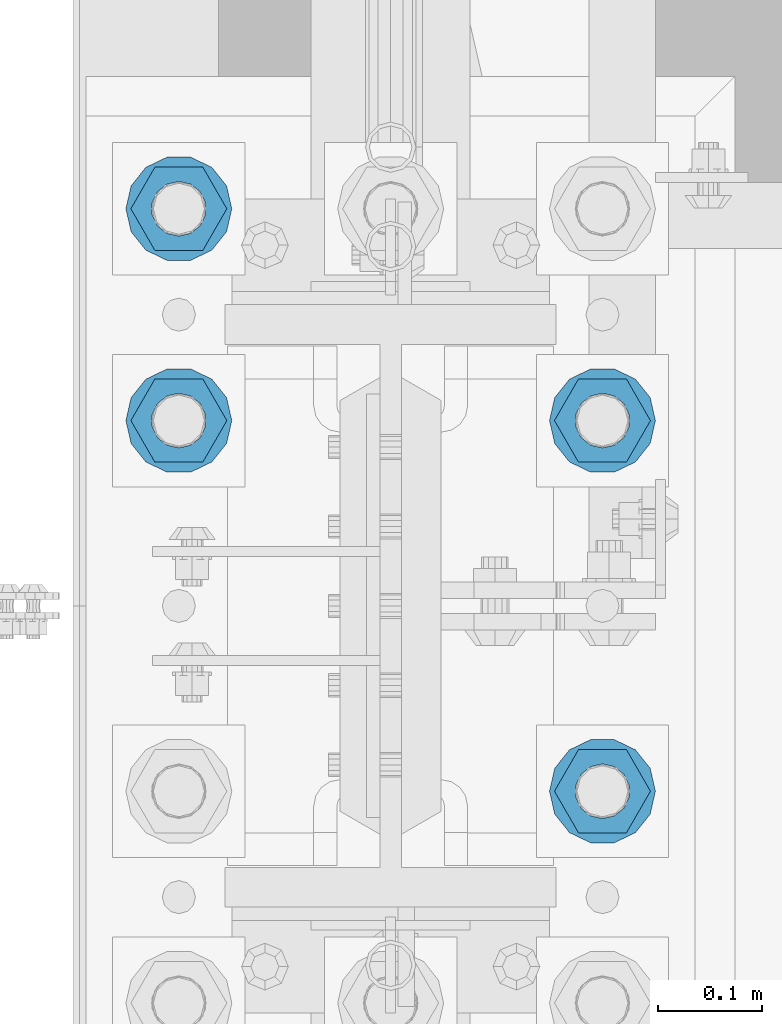
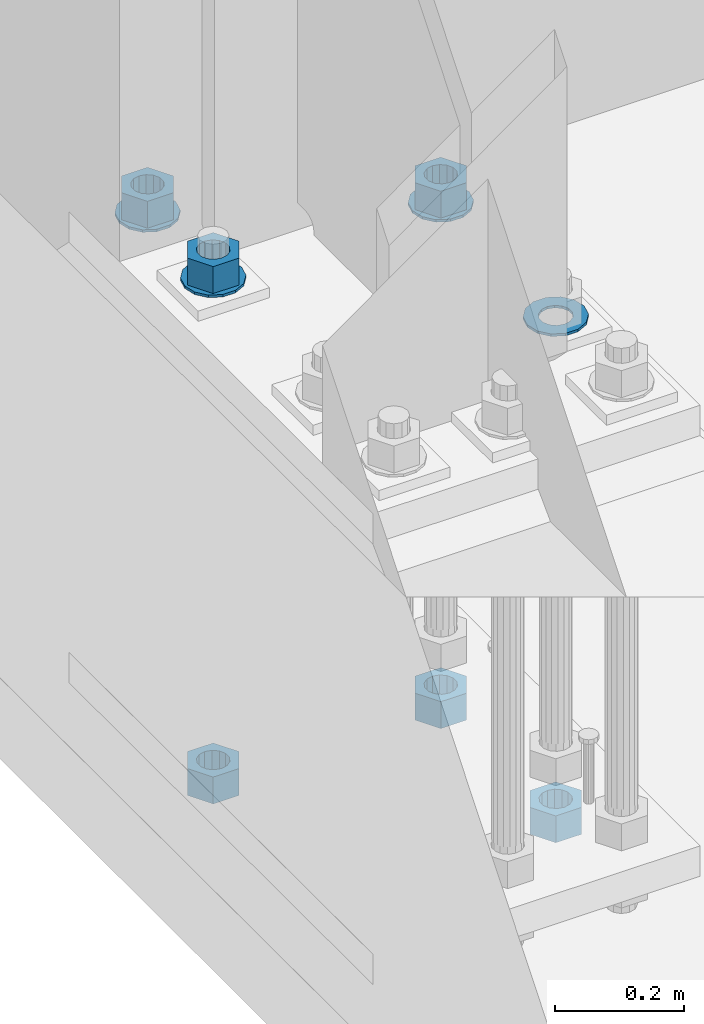
# One storey, part 836 of 1876: 10 columns, 1 element without a shape of its own.
"""IFC2X3 building model written with IfcOpenShell, lengths in millimetres."""

from ifc_helpers import new_model, si_unit, frame, origin_with_axes, place, context, subcontext, project, spatial, faceted_brep, material, type_object, element, aggregate, save


model = new_model("IFC2X3")

# Units and contexts
model_context = context("Model", 3, precision=1e-05, world=origin_with_axes())
body_context = subcontext(model_context, "Body", "Model", "MODEL_VIEW")
ifc_project = project(units=[si_unit("LENGTHUNIT", "METRE", prefix="MILLI"), si_unit("AREAUNIT", "SQUARE_METRE"), si_unit("VOLUMEUNIT", "CUBIC_METRE"), si_unit("MASSUNIT", "GRAM", prefix="KILO"), si_unit("TIMEUNIT", "SECOND"), si_unit("PLANEANGLEUNIT", "RADIAN"), si_unit("SOLIDANGLEUNIT", "STERADIAN"), si_unit("THERMODYNAMICTEMPERATUREUNIT", "DEGREE_CELSIUS"), si_unit("LUMINOUSINTENSITYUNIT", "LUMEN")], contexts=[model_context])

# Site, building, storey
site_placement = place(None, origin_with_axes())
site = spatial("IfcSite", under=ifc_project, at=site_placement, CompositionType="ELEMENT")
building_placement = place(site_placement, origin_with_axes())
building = spatial("IfcBuilding", under=site, at=building_placement, Name="Undefined", CompositionType="ELEMENT")
storey_placement = place(building_placement, origin_with_axes())
storey = spatial("IfcBuildingStorey", under=building, at=storey_placement, Name="Undefined", CompositionType="ELEMENT", Elevation=0.0)

# Assembly, columns
assembly_placement = place(storey_placement, origin_with_axes())
assembly = element("IfcElementAssembly", 1, at=assembly_placement, inside=storey, Name="TEMPLATE", AssemblyPlace="NOTDEFINED", PredefinedType="RIGID_FRAME")
ifc_material_1 = material(Name="STEEL/F436")
column_type_1 = type_object("IfcColumnType", Name="2_WASHER", PredefinedType="NOTDEFINED")
column_1_placement = place(assembly_placement, frame((203.2, 1346.2, 119.0625), z_axis=(0.0, 1.0, 0.0), x_axis=(0.0, 0.0, -1.0)))
column_1 = element("IfcColumn", 2, at=column_1_placement, type_object=column_type_1, material=ifc_material_1, Name="WASHER", ObjectType="2_WASHER", context=body_context, shape_type="Brep", body=[
    faceted_brep([(0.0, -50.7999992370605, 9.09494701772928e-13), (0.0, -45.7692178020588, -22.0412936161442), (4.7625, -45.7692178020588, -22.0412936161442), (4.7625, -50.7999992370605, 9.09494701772928e-13), (0.0, -31.6732814587394, -39.7170387128856), (4.7625, -31.6732814587394, -39.7170387128856), (0.0, -11.3040632752118, -49.5263371950259), (4.7625, -11.3040632752118, -49.5263371950259), (0.0, 11.30406327521, -49.5263371950264), (4.7625, 11.30406327521, -49.5263371950264), (0.0, 31.6732814587385, -39.7170387128867), (4.7625, 31.6732814587385, -39.7170387128867), (0.0, 45.7692178020579, -22.041293616146), (4.7625, 45.7692178020579, -22.041293616146), (0.0, 50.7999992370605, -9.09494701772928e-13), (4.7625, 50.7999992370605, -9.09494701772928e-13), (0.0, 45.7692178020588, 22.0412936161442), (4.7625, 45.7692178020588, 22.0412936161442), (0.0, 31.6732814587394, 39.7170387128856), (4.7625, 31.6732814587394, 39.7170387128856), (0.0, 11.3040632752118, 49.5263371950259), (4.7625, 11.3040632752118, 49.5263371950259), (0.0, -11.30406327521, 49.5263371950264), (4.7625, -11.30406327521, 49.5263371950264), (0.0, -31.6732814587385, 39.7170387128867), (4.7625, -31.6732814587385, 39.7170387128867), (0.0, -45.7692178020579, 22.041293616146), (4.7625, -45.7692178020579, 22.041293616146), (0.0, 0.0, 26.9869995117188), (0.0, 11.7093983825444, 24.3146012721213), (4.7625, 11.7093983825444, 24.3146012721213), (4.7625, 0.0, 26.9869995117188), (0.0, 21.0996520289491, 16.8262864224157), (4.7625, 21.0996520289491, 16.8262864224157), (0.0, 26.3108629296712, 6.00524193584533), (4.7625, 26.3108629296712, 6.00524193584533), (0.0, 26.3108629296712, -6.00524193584533), (4.7625, 26.3108629296712, -6.00524193584533), (0.0, 21.0996520289491, -16.8262864224157), (4.7625, 21.0996520289491, -16.8262864224157), (0.0, 11.7093983825444, -24.3146012721213), (4.7625, 11.7093983825444, -24.3146012721213), (0.0, 0.0, -26.9869995117188), (4.7625, 0.0, -26.9869995117188), (0.0, -11.7093983825444, -24.3146012721213), (4.7625, -11.7093983825444, -24.3146012721213), (0.0, -21.0996520289491, -16.8262864224157), (4.7625, -21.0996520289491, -16.8262864224157), (0.0, -26.3108629296712, -6.00524193584533), (4.7625, -26.3108629296712, -6.00524193584533), (0.0, -26.3108629296712, 6.00524193584533), (4.7625, -26.3108629296712, 6.00524193584533), (0.0, -21.0996520289491, 16.8262864224157), (4.7625, -21.0996520289491, 16.8262864224157), (0.0, -11.7093983825444, 24.3146012721213), (4.7625, -11.7093983825444, 24.3146012721213)], [[[0, 1, 2, 3]], [[1, 4, 5, 2]], [[4, 6, 7, 5]], [[6, 8, 9, 7]], [[8, 10, 11, 9]], [[10, 12, 13, 11]], [[12, 14, 15, 13]], [[14, 16, 17, 15]], [[16, 18, 19, 17]], [[18, 20, 21, 19]], [[20, 22, 23, 21]], [[22, 24, 25, 23]], [[24, 26, 27, 25]], [[26, 0, 3, 27]], [[28, 29, 30, 31]], [[29, 32, 33, 30]], [[32, 34, 35, 33]], [[34, 36, 37, 35]], [[36, 38, 39, 37]], [[38, 40, 41, 39]], [[40, 42, 43, 41]], [[42, 44, 45, 43]], [[44, 46, 47, 45]], [[46, 48, 49, 47]], [[48, 50, 51, 49]], [[50, 52, 53, 51]], [[52, 54, 55, 53]], [[54, 28, 31, 55]], [[5, 7, 9, 11, 13, 15, 17, 19, 21, 23, 25, 27, 3, 2], [33, 35, 37, 39, 41, 43, 45, 47, 49, 51, 53, 55, 31, 30]], [[26, 24, 22, 20, 18, 16, 14, 12, 10, 8, 6, 4, 1, 0], [54, 52, 50, 48, 46, 44, 42, 40, 38, 36, 34, 32, 29, 28]]]),
])
column_2_placement = place(assembly_placement, frame((-203.2, 1701.8, 119.0625), z_axis=(0.0, -1.0, 0.0), x_axis=(0.0, 0.0, -1.0)))
column_2 = element("IfcColumn", 3, at=column_2_placement, type_object=column_type_1, material=ifc_material_1, Name="WASHER", ObjectType="2_WASHER", context=body_context, shape_type="Brep", body=[
    faceted_brep([(0.0, -50.7999992370605, 9.09494701772928e-13), (0.0, -45.7692178020588, -22.0412936161442), (4.7625, -45.7692178020588, -22.0412936161442), (4.7625, -50.7999992370605, 9.09494701772928e-13), (0.0, -31.6732814587394, -39.7170387128856), (4.7625, -31.6732814587394, -39.7170387128856), (0.0, -11.3040632752118, -49.5263371950259), (4.7625, -11.3040632752118, -49.5263371950259), (0.0, 11.30406327521, -49.5263371950264), (4.7625, 11.30406327521, -49.5263371950264), (0.0, 31.6732814587385, -39.7170387128867), (4.7625, 31.6732814587385, -39.7170387128867), (0.0, 45.7692178020579, -22.041293616146), (4.7625, 45.7692178020579, -22.041293616146), (0.0, 50.7999992370605, -9.09494701772928e-13), (4.7625, 50.7999992370605, -9.09494701772928e-13), (0.0, 45.7692178020588, 22.0412936161442), (4.7625, 45.7692178020588, 22.0412936161442), (0.0, 31.6732814587394, 39.7170387128856), (4.7625, 31.6732814587394, 39.7170387128856), (0.0, 11.3040632752118, 49.5263371950259), (4.7625, 11.3040632752118, 49.5263371950259), (0.0, -11.30406327521, 49.5263371950264), (4.7625, -11.30406327521, 49.5263371950264), (0.0, -31.6732814587385, 39.7170387128867), (4.7625, -31.6732814587385, 39.7170387128867), (0.0, -45.7692178020579, 22.041293616146), (4.7625, -45.7692178020579, 22.041293616146), (0.0, 0.0, 26.9869995117188), (0.0, 11.7093983825444, 24.3146012721213), (4.7625, 11.7093983825444, 24.3146012721213), (4.7625, 0.0, 26.9869995117188), (0.0, 21.0996520289491, 16.8262864224157), (4.7625, 21.0996520289491, 16.8262864224157), (0.0, 26.3108629296712, 6.00524193584533), (4.7625, 26.3108629296712, 6.00524193584533), (0.0, 26.3108629296712, -6.00524193584533), (4.7625, 26.3108629296712, -6.00524193584533), (0.0, 21.0996520289491, -16.8262864224157), (4.7625, 21.0996520289491, -16.8262864224157), (0.0, 11.7093983825444, -24.3146012721213), (4.7625, 11.7093983825444, -24.3146012721213), (0.0, 0.0, -26.9869995117188), (4.7625, 0.0, -26.9869995117188), (0.0, -11.7093983825444, -24.3146012721213), (4.7625, -11.7093983825444, -24.3146012721213), (0.0, -21.0996520289491, -16.8262864224157), (4.7625, -21.0996520289491, -16.8262864224157), (0.0, -26.3108629296712, -6.00524193584533), (4.7625, -26.3108629296712, -6.00524193584533), (0.0, -26.3108629296712, 6.00524193584533), (4.7625, -26.3108629296712, 6.00524193584533), (0.0, -21.0996520289491, 16.8262864224157), (4.7625, -21.0996520289491, 16.8262864224157), (0.0, -11.7093983825444, 24.3146012721213), (4.7625, -11.7093983825444, 24.3146012721213)], [[[0, 1, 2, 3]], [[1, 4, 5, 2]], [[4, 6, 7, 5]], [[6, 8, 9, 7]], [[8, 10, 11, 9]], [[10, 12, 13, 11]], [[12, 14, 15, 13]], [[14, 16, 17, 15]], [[16, 18, 19, 17]], [[18, 20, 21, 19]], [[20, 22, 23, 21]], [[22, 24, 25, 23]], [[24, 26, 27, 25]], [[26, 0, 3, 27]], [[28, 29, 30, 31]], [[29, 32, 33, 30]], [[32, 34, 35, 33]], [[34, 36, 37, 35]], [[36, 38, 39, 37]], [[38, 40, 41, 39]], [[40, 42, 43, 41]], [[42, 44, 45, 43]], [[44, 46, 47, 45]], [[46, 48, 49, 47]], [[48, 50, 51, 49]], [[50, 52, 53, 51]], [[52, 54, 55, 53]], [[54, 28, 31, 55]], [[5, 7, 9, 11, 13, 15, 17, 19, 21, 23, 25, 27, 3, 2], [33, 35, 37, 39, 41, 43, 45, 47, 49, 51, 53, 55, 31, 30]], [[26, 24, 22, 20, 18, 16, 14, 12, 10, 8, 6, 4, 1, 0], [54, 52, 50, 48, 46, 44, 42, 40, 38, 36, 34, 32, 29, 28]]]),
])
column_3_placement = place(assembly_placement, frame((203.2, 1701.8, 119.0625), z_axis=(0.0, 1.0, 0.0), x_axis=(0.0, 0.0, -1.0)))
column_3 = element("IfcColumn", 4, at=column_3_placement, type_object=column_type_1, material=ifc_material_1, Name="WASHER", ObjectType="2_WASHER", context=body_context, shape_type="Brep", body=[
    faceted_brep([(0.0, -50.7999992370605, 9.09494701772928e-13), (0.0, -45.7692178020588, -22.0412936161442), (4.7625, -45.7692178020588, -22.0412936161442), (4.7625, -50.7999992370605, 9.09494701772928e-13), (0.0, -31.6732814587394, -39.7170387128856), (4.7625, -31.6732814587394, -39.7170387128856), (0.0, -11.3040632752118, -49.5263371950259), (4.7625, -11.3040632752118, -49.5263371950259), (0.0, 11.30406327521, -49.5263371950264), (4.7625, 11.30406327521, -49.5263371950264), (0.0, 31.6732814587385, -39.7170387128867), (4.7625, 31.6732814587385, -39.7170387128867), (0.0, 45.7692178020579, -22.041293616146), (4.7625, 45.7692178020579, -22.041293616146), (0.0, 50.7999992370605, -9.09494701772928e-13), (4.7625, 50.7999992370605, -9.09494701772928e-13), (0.0, 45.7692178020588, 22.0412936161442), (4.7625, 45.7692178020588, 22.0412936161442), (0.0, 31.6732814587394, 39.7170387128856), (4.7625, 31.6732814587394, 39.7170387128856), (0.0, 11.3040632752118, 49.5263371950259), (4.7625, 11.3040632752118, 49.5263371950259), (0.0, -11.30406327521, 49.5263371950264), (4.7625, -11.30406327521, 49.5263371950264), (0.0, -31.6732814587385, 39.7170387128867), (4.7625, -31.6732814587385, 39.7170387128867), (0.0, -45.7692178020579, 22.041293616146), (4.7625, -45.7692178020579, 22.041293616146), (0.0, 0.0, 26.9869995117188), (0.0, 11.7093983825444, 24.3146012721213), (4.7625, 11.7093983825444, 24.3146012721213), (4.7625, 0.0, 26.9869995117188), (0.0, 21.0996520289491, 16.8262864224157), (4.7625, 21.0996520289491, 16.8262864224157), (0.0, 26.3108629296712, 6.00524193584533), (4.7625, 26.3108629296712, 6.00524193584533), (0.0, 26.3108629296712, -6.00524193584533), (4.7625, 26.3108629296712, -6.00524193584533), (0.0, 21.0996520289491, -16.8262864224157), (4.7625, 21.0996520289491, -16.8262864224157), (0.0, 11.7093983825444, -24.3146012721213), (4.7625, 11.7093983825444, -24.3146012721213), (0.0, 0.0, -26.9869995117188), (4.7625, 0.0, -26.9869995117188), (0.0, -11.7093983825444, -24.3146012721213), (4.7625, -11.7093983825444, -24.3146012721213), (0.0, -21.0996520289491, -16.8262864224157), (4.7625, -21.0996520289491, -16.8262864224157), (0.0, -26.3108629296712, -6.00524193584533), (4.7625, -26.3108629296712, -6.00524193584533), (0.0, -26.3108629296712, 6.00524193584533), (4.7625, -26.3108629296712, 6.00524193584533), (0.0, -21.0996520289491, 16.8262864224157), (4.7625, -21.0996520289491, 16.8262864224157), (0.0, -11.7093983825444, 24.3146012721213), (4.7625, -11.7093983825444, 24.3146012721213)], [[[0, 1, 2, 3]], [[1, 4, 5, 2]], [[4, 6, 7, 5]], [[6, 8, 9, 7]], [[8, 10, 11, 9]], [[10, 12, 13, 11]], [[12, 14, 15, 13]], [[14, 16, 17, 15]], [[16, 18, 19, 17]], [[18, 20, 21, 19]], [[20, 22, 23, 21]], [[22, 24, 25, 23]], [[24, 26, 27, 25]], [[26, 0, 3, 27]], [[28, 29, 30, 31]], [[29, 32, 33, 30]], [[32, 34, 35, 33]], [[34, 36, 37, 35]], [[36, 38, 39, 37]], [[38, 40, 41, 39]], [[40, 42, 43, 41]], [[42, 44, 45, 43]], [[44, 46, 47, 45]], [[46, 48, 49, 47]], [[48, 50, 51, 49]], [[50, 52, 53, 51]], [[52, 54, 55, 53]], [[54, 28, 31, 55]], [[5, 7, 9, 11, 13, 15, 17, 19, 21, 23, 25, 27, 3, 2], [33, 35, 37, 39, 41, 43, 45, 47, 49, 51, 53, 55, 31, 30]], [[26, 24, 22, 20, 18, 16, 14, 12, 10, 8, 6, 4, 1, 0], [54, 52, 50, 48, 46, 44, 42, 40, 38, 36, 34, 32, 29, 28]]]),
])
column_4_placement = place(assembly_placement, frame((-203.2, 1905.0, 119.0625), z_axis=(0.0, -1.0, 0.0), x_axis=(0.0, 0.0, -1.0)))
column_4 = element("IfcColumn", 5, at=column_4_placement, type_object=column_type_1, material=ifc_material_1, Name="WASHER", ObjectType="2_WASHER", context=body_context, shape_type="Brep", body=[
    faceted_brep([(0.0, -50.7999992370605, 9.09494701772928e-13), (0.0, -45.7692178020588, -22.0412936161442), (4.7625, -45.7692178020588, -22.0412936161442), (4.7625, -50.7999992370605, 9.09494701772928e-13), (0.0, -31.6732814587394, -39.7170387128856), (4.7625, -31.6732814587394, -39.7170387128856), (0.0, -11.3040632752118, -49.5263371950259), (4.7625, -11.3040632752118, -49.5263371950259), (0.0, 11.30406327521, -49.5263371950264), (4.7625, 11.30406327521, -49.5263371950264), (0.0, 31.6732814587385, -39.7170387128867), (4.7625, 31.6732814587385, -39.7170387128867), (0.0, 45.7692178020579, -22.041293616146), (4.7625, 45.7692178020579, -22.041293616146), (0.0, 50.7999992370605, -9.09494701772928e-13), (4.7625, 50.7999992370605, -9.09494701772928e-13), (0.0, 45.7692178020588, 22.0412936161442), (4.7625, 45.7692178020588, 22.0412936161442), (0.0, 31.6732814587394, 39.7170387128856), (4.7625, 31.6732814587394, 39.7170387128856), (0.0, 11.3040632752118, 49.5263371950259), (4.7625, 11.3040632752118, 49.5263371950259), (0.0, -11.30406327521, 49.5263371950264), (4.7625, -11.30406327521, 49.5263371950264), (0.0, -31.6732814587385, 39.7170387128867), (4.7625, -31.6732814587385, 39.7170387128867), (0.0, -45.7692178020579, 22.041293616146), (4.7625, -45.7692178020579, 22.041293616146), (0.0, 0.0, 26.9869995117188), (0.0, 11.7093983825444, 24.3146012721213), (4.7625, 11.7093983825444, 24.3146012721213), (4.7625, 0.0, 26.9869995117188), (0.0, 21.0996520289491, 16.8262864224157), (4.7625, 21.0996520289491, 16.8262864224157), (0.0, 26.3108629296712, 6.00524193584533), (4.7625, 26.3108629296712, 6.00524193584533), (0.0, 26.3108629296712, -6.00524193584533), (4.7625, 26.3108629296712, -6.00524193584533), (0.0, 21.0996520289491, -16.8262864224157), (4.7625, 21.0996520289491, -16.8262864224157), (0.0, 11.7093983825444, -24.3146012721213), (4.7625, 11.7093983825444, -24.3146012721213), (0.0, 0.0, -26.9869995117188), (4.7625, 0.0, -26.9869995117188), (0.0, -11.7093983825444, -24.3146012721213), (4.7625, -11.7093983825444, -24.3146012721213), (0.0, -21.0996520289491, -16.8262864224157), (4.7625, -21.0996520289491, -16.8262864224157), (0.0, -26.3108629296712, -6.00524193584533), (4.7625, -26.3108629296712, -6.00524193584533), (0.0, -26.3108629296712, 6.00524193584533), (4.7625, -26.3108629296712, 6.00524193584533), (0.0, -21.0996520289491, 16.8262864224157), (4.7625, -21.0996520289491, 16.8262864224157), (0.0, -11.7093983825444, 24.3146012721213), (4.7625, -11.7093983825444, 24.3146012721213)], [[[0, 1, 2, 3]], [[1, 4, 5, 2]], [[4, 6, 7, 5]], [[6, 8, 9, 7]], [[8, 10, 11, 9]], [[10, 12, 13, 11]], [[12, 14, 15, 13]], [[14, 16, 17, 15]], [[16, 18, 19, 17]], [[18, 20, 21, 19]], [[20, 22, 23, 21]], [[22, 24, 25, 23]], [[24, 26, 27, 25]], [[26, 0, 3, 27]], [[28, 29, 30, 31]], [[29, 32, 33, 30]], [[32, 34, 35, 33]], [[34, 36, 37, 35]], [[36, 38, 39, 37]], [[38, 40, 41, 39]], [[40, 42, 43, 41]], [[42, 44, 45, 43]], [[44, 46, 47, 45]], [[46, 48, 49, 47]], [[48, 50, 51, 49]], [[50, 52, 53, 51]], [[52, 54, 55, 53]], [[54, 28, 31, 55]], [[5, 7, 9, 11, 13, 15, 17, 19, 21, 23, 25, 27, 3, 2], [33, 35, 37, 39, 41, 43, 45, 47, 49, 51, 53, 55, 31, 30]], [[26, 24, 22, 20, 18, 16, 14, 12, 10, 8, 6, 4, 1, 0], [54, 52, 50, 48, 46, 44, 42, 40, 38, 36, 34, 32, 29, 28]]]),
])
ifc_material_2 = material(Name="STEEL/A563")
column_type_2 = type_object("IfcColumnType", Name="2_HEAVY_HEX_NUT", PredefinedType="NOTDEFINED")
column_5_placement = place(assembly_placement, frame((203.2, 1346.2, -793.75), z_axis=(0.0, 1.0, 0.0), x_axis=(0.0, 0.0, -1.0)))
column_5 = element("IfcColumn", 6, at=column_5_placement, type_object=column_type_2, material=ifc_material_2, Name="NUT", ObjectType="2_HEAVY_HEX_NUT", context=body_context, shape_type="Brep", body=[
    faceted_brep([(0.0, -46.0369987487793, 9.09494701772928e-13), (0.0, -23.0184993743896, -39.869213104248), (50.8, -23.0184993743896, -39.869213104248), (50.8, -46.0369987487793, 9.09494701772928e-13), (0.0, 23.0184993743896, -39.869213104248), (50.8, 23.0184993743896, -39.869213104248), (0.0, 46.0369987487793, -9.09494701772928e-13), (50.8, 46.0369987487793, -9.09494701772928e-13), (0.0, 23.0184993743896, 39.869213104248), (50.8, 23.0184993743896, 39.869213104248), (0.0, -23.0184993743896, 39.869213104248), (50.8, -23.0184993743896, 39.869213104248), (0.0, 0.0, 26.1940002441406), (0.0, 11.3650617044514, 23.5999013092769), (50.8, 11.3650617044513, 23.5999013092771), (50.8, 0.0, 26.1940002441406), (0.0, 20.4791109456437, 16.3316083006703), (50.8, 20.4791109456439, 16.3316083006703), (0.0, 25.5370200498346, 5.82867859874477), (50.8, 25.5370200498343, 5.82867859874455), (0.0, 25.5370200498346, -5.82867859874477), (50.8, 25.5370200498343, -5.82867859874455), (0.0, 20.4791109456437, -16.3316083006703), (50.8, 20.4791109456439, -16.3316083006703), (0.0, 11.3650617044514, -23.5999013092769), (50.8, 11.3650617044514, -23.5999013092771), (0.0, 0.0, -26.1940002441406), (50.8, 0.0, -26.1940002441406), (0.0, -11.3650617044514, -23.5999013092769), (50.8, -11.3650617044513, -23.5999013092771), (0.0, -20.4791109456437, -16.3316083006703), (50.8, -20.4791109456439, -16.3316083006703), (0.0, -25.5370200498346, -5.82867859874477), (50.8, -25.5370200498343, -5.82867859874455), (0.0, -25.5370200498346, 5.82867859874477), (50.8, -25.5370200498343, 5.82867859874455), (0.0, -20.4791109456437, 16.3316083006703), (50.8, -20.4791109456439, 16.3316083006703), (0.0, -11.3650617044514, 23.5999013092769), (50.8, -11.3650617044514, 23.5999013092771)], [[[0, 1, 2, 3]], [[1, 4, 5, 2]], [[4, 6, 7, 5]], [[6, 8, 9, 7]], [[8, 10, 11, 9]], [[10, 0, 3, 11]], [[12, 13, 14, 15]], [[13, 16, 17, 14]], [[16, 18, 19, 17]], [[18, 20, 21, 19]], [[20, 22, 23, 21]], [[22, 24, 25, 23]], [[24, 26, 27, 25]], [[26, 28, 29, 27]], [[28, 30, 31, 29]], [[30, 32, 33, 31]], [[32, 34, 35, 33]], [[34, 36, 37, 35]], [[36, 38, 39, 37]], [[38, 12, 15, 39]], [[5, 7, 9, 11, 3, 2], [17, 19, 21, 23, 25, 27, 29, 31, 33, 35, 37, 39, 15, 14]], [[10, 8, 6, 4, 1, 0], [38, 36, 34, 32, 30, 28, 26, 24, 22, 20, 18, 16, 13, 12]]]),
])
column_6_placement = place(assembly_placement, frame((-203.2, 1701.8, 169.8625), z_axis=(0.0, -1.0, 0.0), x_axis=(0.0, 0.0, -1.0)))
column_6 = element("IfcColumn", 7, at=column_6_placement, type_object=column_type_2, material=ifc_material_2, Name="NUT", ObjectType="2_HEAVY_HEX_NUT", context=body_context, shape_type="Brep", body=[
    faceted_brep([(0.0, -46.0369987487793, 9.09494701772928e-13), (0.0, -23.0184993743896, -39.869213104248), (50.8, -23.0184993743896, -39.869213104248), (50.8, -46.0369987487793, 9.09494701772928e-13), (0.0, 23.0184993743896, -39.869213104248), (50.8, 23.0184993743896, -39.869213104248), (0.0, 46.0369987487793, -9.09494701772928e-13), (50.8, 46.0369987487793, -9.09494701772928e-13), (0.0, 23.0184993743896, 39.869213104248), (50.8, 23.0184993743896, 39.869213104248), (0.0, -23.0184993743896, 39.869213104248), (50.8, -23.0184993743896, 39.869213104248), (0.0, 0.0, 26.1940002441406), (0.0, 11.3650617044514, 23.5999013092769), (50.8, 11.3650617044513, 23.5999013092771), (50.8, 0.0, 26.1940002441406), (0.0, 20.4791109456437, 16.3316083006703), (50.8, 20.4791109456439, 16.3316083006703), (0.0, 25.5370200498346, 5.82867859874477), (50.8, 25.5370200498343, 5.82867859874455), (0.0, 25.5370200498346, -5.82867859874477), (50.8, 25.5370200498343, -5.82867859874455), (0.0, 20.4791109456437, -16.3316083006703), (50.8, 20.4791109456439, -16.3316083006703), (0.0, 11.3650617044514, -23.5999013092769), (50.8, 11.3650617044514, -23.5999013092771), (0.0, 0.0, -26.1940002441406), (50.8, 0.0, -26.1940002441406), (0.0, -11.3650617044514, -23.5999013092769), (50.8, -11.3650617044513, -23.5999013092771), (0.0, -20.4791109456437, -16.3316083006703), (50.8, -20.4791109456439, -16.3316083006703), (0.0, -25.5370200498346, -5.82867859874477), (50.8, -25.5370200498343, -5.82867859874455), (0.0, -25.5370200498346, 5.82867859874477), (50.8, -25.5370200498343, 5.82867859874455), (0.0, -20.4791109456437, 16.3316083006703), (50.8, -20.4791109456439, 16.3316083006703), (0.0, -11.3650617044514, 23.5999013092769), (50.8, -11.3650617044514, 23.5999013092771)], [[[0, 1, 2, 3]], [[1, 4, 5, 2]], [[4, 6, 7, 5]], [[6, 8, 9, 7]], [[8, 10, 11, 9]], [[10, 0, 3, 11]], [[12, 13, 14, 15]], [[13, 16, 17, 14]], [[16, 18, 19, 17]], [[18, 20, 21, 19]], [[20, 22, 23, 21]], [[22, 24, 25, 23]], [[24, 26, 27, 25]], [[26, 28, 29, 27]], [[28, 30, 31, 29]], [[30, 32, 33, 31]], [[32, 34, 35, 33]], [[34, 36, 37, 35]], [[36, 38, 39, 37]], [[38, 12, 15, 39]], [[5, 7, 9, 11, 3, 2], [17, 19, 21, 23, 25, 27, 29, 31, 33, 35, 37, 39, 15, 14]], [[10, 8, 6, 4, 1, 0], [38, 36, 34, 32, 30, 28, 26, 24, 22, 20, 18, 16, 13, 12]]]),
])
column_7_placement = place(assembly_placement, frame((-203.2, 1701.8, -793.75), z_axis=(0.0, -1.0, 0.0), x_axis=(0.0, 0.0, -1.0)))
column_7 = element("IfcColumn", 8, at=column_7_placement, type_object=column_type_2, material=ifc_material_2, Name="NUT", ObjectType="2_HEAVY_HEX_NUT", context=body_context, shape_type="Brep", body=[
    faceted_brep([(0.0, -46.0369987487793, 9.09494701772928e-13), (0.0, -23.0184993743896, -39.869213104248), (50.8, -23.0184993743896, -39.869213104248), (50.8, -46.0369987487793, 9.09494701772928e-13), (0.0, 23.0184993743896, -39.869213104248), (50.8, 23.0184993743896, -39.869213104248), (0.0, 46.0369987487793, -9.09494701772928e-13), (50.8, 46.0369987487793, -9.09494701772928e-13), (0.0, 23.0184993743896, 39.869213104248), (50.8, 23.0184993743896, 39.869213104248), (0.0, -23.0184993743896, 39.869213104248), (50.8, -23.0184993743896, 39.869213104248), (0.0, 0.0, 26.1940002441406), (0.0, 11.3650617044514, 23.5999013092769), (50.8, 11.3650617044513, 23.5999013092771), (50.8, 0.0, 26.1940002441406), (0.0, 20.4791109456437, 16.3316083006703), (50.8, 20.4791109456439, 16.3316083006703), (0.0, 25.5370200498346, 5.82867859874477), (50.8, 25.5370200498343, 5.82867859874455), (0.0, 25.5370200498346, -5.82867859874477), (50.8, 25.5370200498343, -5.82867859874455), (0.0, 20.4791109456437, -16.3316083006703), (50.8, 20.4791109456439, -16.3316083006703), (0.0, 11.3650617044514, -23.5999013092769), (50.8, 11.3650617044514, -23.5999013092771), (0.0, 0.0, -26.1940002441406), (50.8, 0.0, -26.1940002441406), (0.0, -11.3650617044514, -23.5999013092769), (50.8, -11.3650617044513, -23.5999013092771), (0.0, -20.4791109456437, -16.3316083006703), (50.8, -20.4791109456439, -16.3316083006703), (0.0, -25.5370200498346, -5.82867859874477), (50.8, -25.5370200498343, -5.82867859874455), (0.0, -25.5370200498346, 5.82867859874477), (50.8, -25.5370200498343, 5.82867859874455), (0.0, -20.4791109456437, 16.3316083006703), (50.8, -20.4791109456439, 16.3316083006703), (0.0, -11.3650617044514, 23.5999013092769), (50.8, -11.3650617044514, 23.5999013092771)], [[[0, 1, 2, 3]], [[1, 4, 5, 2]], [[4, 6, 7, 5]], [[6, 8, 9, 7]], [[8, 10, 11, 9]], [[10, 0, 3, 11]], [[12, 13, 14, 15]], [[13, 16, 17, 14]], [[16, 18, 19, 17]], [[18, 20, 21, 19]], [[20, 22, 23, 21]], [[22, 24, 25, 23]], [[24, 26, 27, 25]], [[26, 28, 29, 27]], [[28, 30, 31, 29]], [[30, 32, 33, 31]], [[32, 34, 35, 33]], [[34, 36, 37, 35]], [[36, 38, 39, 37]], [[38, 12, 15, 39]], [[5, 7, 9, 11, 3, 2], [17, 19, 21, 23, 25, 27, 29, 31, 33, 35, 37, 39, 15, 14]], [[10, 8, 6, 4, 1, 0], [38, 36, 34, 32, 30, 28, 26, 24, 22, 20, 18, 16, 13, 12]]]),
])
column_8_placement = place(assembly_placement, frame((203.2, 1701.8, 169.8625), z_axis=(0.0, 1.0, 0.0), x_axis=(0.0, 0.0, -1.0)))
column_8 = element("IfcColumn", 9, at=column_8_placement, type_object=column_type_2, material=ifc_material_2, Name="NUT", ObjectType="2_HEAVY_HEX_NUT", context=body_context, shape_type="Brep", body=[
    faceted_brep([(0.0, -46.0369987487793, 9.09494701772928e-13), (0.0, -23.0184993743896, -39.869213104248), (50.8, -23.0184993743896, -39.869213104248), (50.8, -46.0369987487793, 9.09494701772928e-13), (0.0, 23.0184993743896, -39.869213104248), (50.8, 23.0184993743896, -39.869213104248), (0.0, 46.0369987487793, -9.09494701772928e-13), (50.8, 46.0369987487793, -9.09494701772928e-13), (0.0, 23.0184993743896, 39.869213104248), (50.8, 23.0184993743896, 39.869213104248), (0.0, -23.0184993743896, 39.869213104248), (50.8, -23.0184993743896, 39.869213104248), (0.0, 0.0, 26.1940002441406), (0.0, 11.3650617044514, 23.5999013092769), (50.8, 11.3650617044513, 23.5999013092771), (50.8, 0.0, 26.1940002441406), (0.0, 20.4791109456437, 16.3316083006703), (50.8, 20.4791109456439, 16.3316083006703), (0.0, 25.5370200498346, 5.82867859874477), (50.8, 25.5370200498343, 5.82867859874455), (0.0, 25.5370200498346, -5.82867859874477), (50.8, 25.5370200498343, -5.82867859874455), (0.0, 20.4791109456437, -16.3316083006703), (50.8, 20.4791109456439, -16.3316083006703), (0.0, 11.3650617044514, -23.5999013092769), (50.8, 11.3650617044514, -23.5999013092771), (0.0, 0.0, -26.1940002441406), (50.8, 0.0, -26.1940002441406), (0.0, -11.3650617044514, -23.5999013092769), (50.8, -11.3650617044513, -23.5999013092771), (0.0, -20.4791109456437, -16.3316083006703), (50.8, -20.4791109456439, -16.3316083006703), (0.0, -25.5370200498346, -5.82867859874477), (50.8, -25.5370200498343, -5.82867859874455), (0.0, -25.5370200498346, 5.82867859874477), (50.8, -25.5370200498343, 5.82867859874455), (0.0, -20.4791109456437, 16.3316083006703), (50.8, -20.4791109456439, 16.3316083006703), (0.0, -11.3650617044514, 23.5999013092769), (50.8, -11.3650617044514, 23.5999013092771)], [[[0, 1, 2, 3]], [[1, 4, 5, 2]], [[4, 6, 7, 5]], [[6, 8, 9, 7]], [[8, 10, 11, 9]], [[10, 0, 3, 11]], [[12, 13, 14, 15]], [[13, 16, 17, 14]], [[16, 18, 19, 17]], [[18, 20, 21, 19]], [[20, 22, 23, 21]], [[22, 24, 25, 23]], [[24, 26, 27, 25]], [[26, 28, 29, 27]], [[28, 30, 31, 29]], [[30, 32, 33, 31]], [[32, 34, 35, 33]], [[34, 36, 37, 35]], [[36, 38, 39, 37]], [[38, 12, 15, 39]], [[5, 7, 9, 11, 3, 2], [17, 19, 21, 23, 25, 27, 29, 31, 33, 35, 37, 39, 15, 14]], [[10, 8, 6, 4, 1, 0], [38, 36, 34, 32, 30, 28, 26, 24, 22, 20, 18, 16, 13, 12]]]),
])
column_9_placement = place(assembly_placement, frame((203.2, 1701.8, -793.75), z_axis=(0.0, 1.0, 0.0), x_axis=(0.0, 0.0, -1.0)))
column_9 = element("IfcColumn", 10, at=column_9_placement, type_object=column_type_2, material=ifc_material_2, Name="NUT", ObjectType="2_HEAVY_HEX_NUT", context=body_context, shape_type="Brep", body=[
    faceted_brep([(0.0, -46.0369987487793, 9.09494701772928e-13), (0.0, -23.0184993743896, -39.869213104248), (50.8, -23.0184993743896, -39.869213104248), (50.8, -46.0369987487793, 9.09494701772928e-13), (0.0, 23.0184993743896, -39.869213104248), (50.8, 23.0184993743896, -39.869213104248), (0.0, 46.0369987487793, -9.09494701772928e-13), (50.8, 46.0369987487793, -9.09494701772928e-13), (0.0, 23.0184993743896, 39.869213104248), (50.8, 23.0184993743896, 39.869213104248), (0.0, -23.0184993743896, 39.869213104248), (50.8, -23.0184993743896, 39.869213104248), (0.0, 0.0, 26.1940002441406), (0.0, 11.3650617044514, 23.5999013092769), (50.8, 11.3650617044513, 23.5999013092771), (50.8, 0.0, 26.1940002441406), (0.0, 20.4791109456437, 16.3316083006703), (50.8, 20.4791109456439, 16.3316083006703), (0.0, 25.5370200498346, 5.82867859874477), (50.8, 25.5370200498343, 5.82867859874455), (0.0, 25.5370200498346, -5.82867859874477), (50.8, 25.5370200498343, -5.82867859874455), (0.0, 20.4791109456437, -16.3316083006703), (50.8, 20.4791109456439, -16.3316083006703), (0.0, 11.3650617044514, -23.5999013092769), (50.8, 11.3650617044514, -23.5999013092771), (0.0, 0.0, -26.1940002441406), (50.8, 0.0, -26.1940002441406), (0.0, -11.3650617044514, -23.5999013092769), (50.8, -11.3650617044513, -23.5999013092771), (0.0, -20.4791109456437, -16.3316083006703), (50.8, -20.4791109456439, -16.3316083006703), (0.0, -25.5370200498346, -5.82867859874477), (50.8, -25.5370200498343, -5.82867859874455), (0.0, -25.5370200498346, 5.82867859874477), (50.8, -25.5370200498343, 5.82867859874455), (0.0, -20.4791109456437, 16.3316083006703), (50.8, -20.4791109456439, 16.3316083006703), (0.0, -11.3650617044514, 23.5999013092769), (50.8, -11.3650617044514, 23.5999013092771)], [[[0, 1, 2, 3]], [[1, 4, 5, 2]], [[4, 6, 7, 5]], [[6, 8, 9, 7]], [[8, 10, 11, 9]], [[10, 0, 3, 11]], [[12, 13, 14, 15]], [[13, 16, 17, 14]], [[16, 18, 19, 17]], [[18, 20, 21, 19]], [[20, 22, 23, 21]], [[22, 24, 25, 23]], [[24, 26, 27, 25]], [[26, 28, 29, 27]], [[28, 30, 31, 29]], [[30, 32, 33, 31]], [[32, 34, 35, 33]], [[34, 36, 37, 35]], [[36, 38, 39, 37]], [[38, 12, 15, 39]], [[5, 7, 9, 11, 3, 2], [17, 19, 21, 23, 25, 27, 29, 31, 33, 35, 37, 39, 15, 14]], [[10, 8, 6, 4, 1, 0], [38, 36, 34, 32, 30, 28, 26, 24, 22, 20, 18, 16, 13, 12]]]),
])
column_10_placement = place(assembly_placement, frame((-203.2, 1905.0, 169.8625), z_axis=(0.0, -1.0, 0.0), x_axis=(0.0, 0.0, -1.0)))
column_10 = element("IfcColumn", 11, at=column_10_placement, type_object=column_type_2, material=ifc_material_2, Name="NUT", ObjectType="2_HEAVY_HEX_NUT", context=body_context, shape_type="Brep", body=[
    faceted_brep([(0.0, -46.0369987487793, 9.09494701772928e-13), (0.0, -23.0184993743896, -39.869213104248), (50.8, -23.0184993743896, -39.869213104248), (50.8, -46.0369987487793, 9.09494701772928e-13), (0.0, 23.0184993743896, -39.869213104248), (50.8, 23.0184993743896, -39.869213104248), (0.0, 46.0369987487793, -9.09494701772928e-13), (50.8, 46.0369987487793, -9.09494701772928e-13), (0.0, 23.0184993743896, 39.869213104248), (50.8, 23.0184993743896, 39.869213104248), (0.0, -23.0184993743896, 39.869213104248), (50.8, -23.0184993743896, 39.869213104248), (0.0, 0.0, 26.1940002441406), (0.0, 11.3650617044514, 23.5999013092769), (50.8, 11.3650617044513, 23.5999013092771), (50.8, 0.0, 26.1940002441406), (0.0, 20.4791109456437, 16.3316083006703), (50.8, 20.4791109456439, 16.3316083006703), (0.0, 25.5370200498346, 5.82867859874477), (50.8, 25.5370200498343, 5.82867859874455), (0.0, 25.5370200498346, -5.82867859874477), (50.8, 25.5370200498343, -5.82867859874455), (0.0, 20.4791109456437, -16.3316083006703), (50.8, 20.4791109456439, -16.3316083006703), (0.0, 11.3650617044514, -23.5999013092769), (50.8, 11.3650617044514, -23.5999013092771), (0.0, 0.0, -26.1940002441406), (50.8, 0.0, -26.1940002441406), (0.0, -11.3650617044514, -23.5999013092769), (50.8, -11.3650617044513, -23.5999013092771), (0.0, -20.4791109456437, -16.3316083006703), (50.8, -20.4791109456439, -16.3316083006703), (0.0, -25.5370200498346, -5.82867859874477), (50.8, -25.5370200498343, -5.82867859874455), (0.0, -25.5370200498346, 5.82867859874477), (50.8, -25.5370200498343, 5.82867859874455), (0.0, -20.4791109456437, 16.3316083006703), (50.8, -20.4791109456439, 16.3316083006703), (0.0, -11.3650617044514, 23.5999013092769), (50.8, -11.3650617044514, 23.5999013092771)], [[[0, 1, 2, 3]], [[1, 4, 5, 2]], [[4, 6, 7, 5]], [[6, 8, 9, 7]], [[8, 10, 11, 9]], [[10, 0, 3, 11]], [[12, 13, 14, 15]], [[13, 16, 17, 14]], [[16, 18, 19, 17]], [[18, 20, 21, 19]], [[20, 22, 23, 21]], [[22, 24, 25, 23]], [[24, 26, 27, 25]], [[26, 28, 29, 27]], [[28, 30, 31, 29]], [[30, 32, 33, 31]], [[32, 34, 35, 33]], [[34, 36, 37, 35]], [[36, 38, 39, 37]], [[38, 12, 15, 39]], [[5, 7, 9, 11, 3, 2], [17, 19, 21, 23, 25, 27, 29, 31, 33, 35, 37, 39, 15, 14]], [[10, 8, 6, 4, 1, 0], [38, 36, 34, 32, 30, 28, 26, 24, 22, 20, 18, 16, 13, 12]]]),
])
aggregate(assembly, [column_1, column_5, column_6, column_2, column_7, column_8, column_3, column_9, column_10, column_4])

save(model, "model.ifc")
